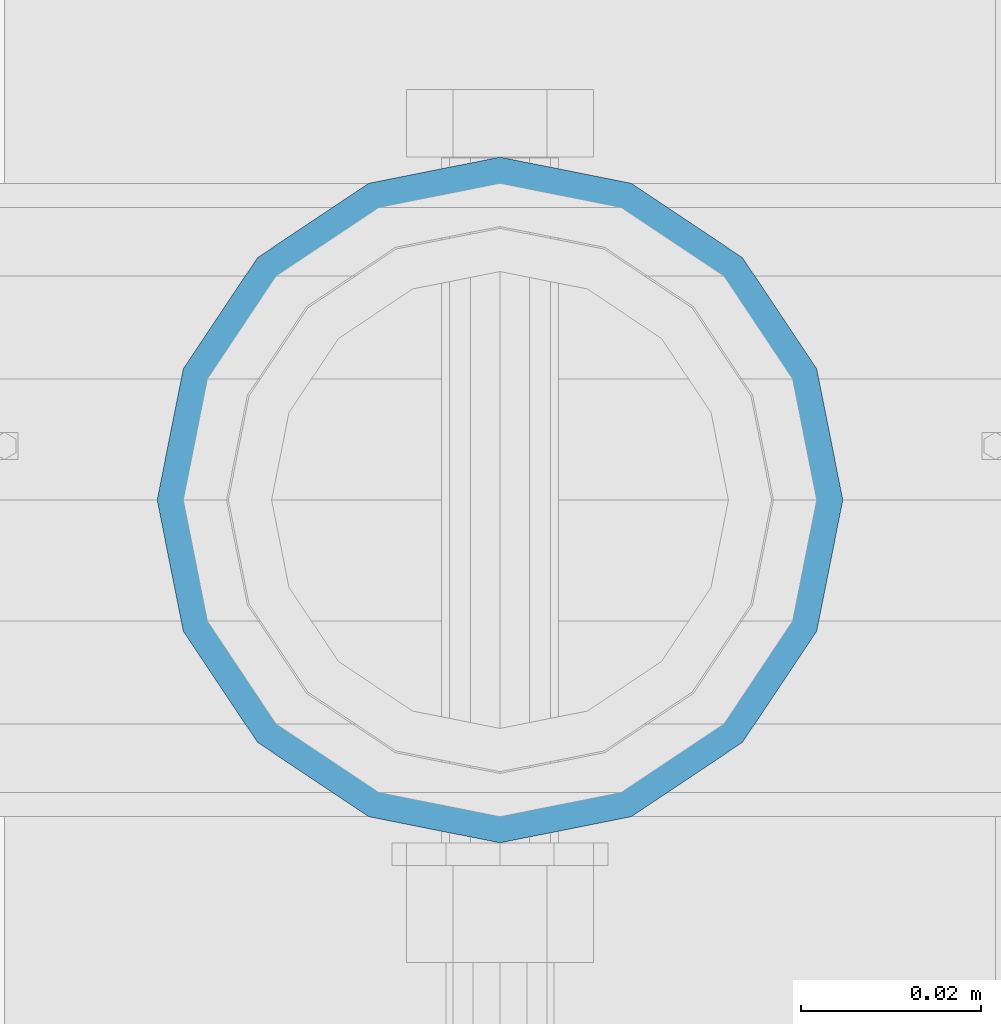
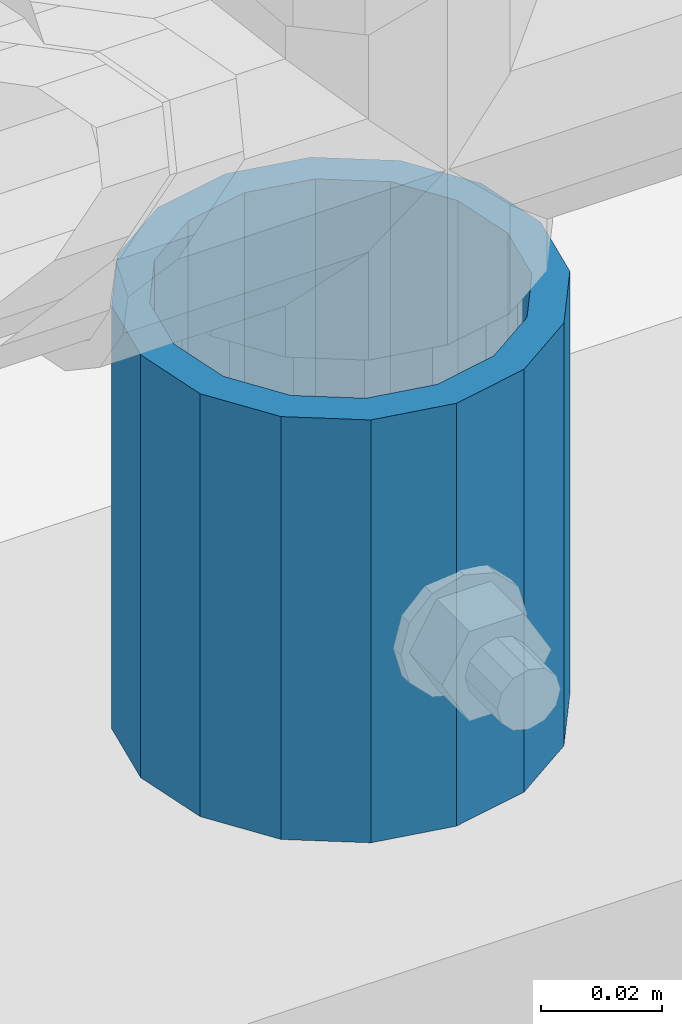
# One storey, part 79 of 240: 1 column.
"""IFC2X3 building model written with IfcOpenShell, lengths in millimetres."""

from ifc_helpers import new_model, si_unit, frame, origin_with_axes, place, context, subcontext, project, spatial, faceted_brep, material, type_object, element, save


model = new_model("IFC2X3")

# Units and contexts
model_context = context("Model", 3, precision=1e-05, world=origin_with_axes())
body_context = subcontext(model_context, "Body", "Model", "MODEL_VIEW")
ifc_project = project(units=[si_unit("LENGTHUNIT", "METRE", prefix="MILLI"), si_unit("AREAUNIT", "SQUARE_METRE"), si_unit("VOLUMEUNIT", "CUBIC_METRE"), si_unit("MASSUNIT", "GRAM", prefix="KILO"), si_unit("TIMEUNIT", "SECOND"), si_unit("PLANEANGLEUNIT", "RADIAN"), si_unit("SOLIDANGLEUNIT", "STERADIAN"), si_unit("THERMODYNAMICTEMPERATUREUNIT", "DEGREE_CELSIUS"), si_unit("LUMINOUSINTENSITYUNIT", "LUMEN")], contexts=[model_context])

# Site, building, storey
site_placement = place(None, origin_with_axes())
site = spatial("IfcSite", under=ifc_project, at=site_placement, CompositionType="ELEMENT")
building_placement = place(site_placement, origin_with_axes())
building = spatial("IfcBuilding", under=site, at=building_placement, Name="Standard", CompositionType="ELEMENT")
storey_placement = place(building_placement, origin_with_axes())
storey = spatial("IfcBuildingStorey", under=building, at=storey_placement, Name="Undefined", CompositionType="ELEMENT", Elevation=0.0)

# Column
ifc_material = material()
column_type = type_object("IfcColumnType", PredefinedType="NOTDEFINED")
column_placement = place(storey_placement, frame((48045.0, 34664.5, 168.02), z_axis=(0.0, 1.0, 0.0), x_axis=(0.0, 0.0, 1.0)))
element("IfcColumn", 1, at=column_placement, inside=storey, type_object=column_type, material=ifc_material, context=body_context, shape_type="Brep", body=[
    faceted_brep([(0.0, -31.75, 0.0), (0.0, -29.3331751572332, 12.1501989775934), (85.0, -29.3331751572332, 12.1501989775934), (85.0, -31.75, 0.0), (0.0, -22.4506403026753, 22.4506403026753), (85.0, -22.4506403026753, 22.4506403026753), (0.0, -12.1501989775934, 29.3331751572332), (85.0, -12.1501989775934, 29.3331751572332), (0.0, 0.0, 31.75), (85.0, 0.0, 31.75), (0.0, 12.1501989775934, 29.3331751572332), (85.0, 12.1501989775934, 29.3331751572332), (0.0, 22.4506403026753, 22.4506403026753), (85.0, 22.4506403026753, 22.4506403026753), (0.0, 29.3331751572332, 12.1501989775934), (85.0, 29.3331751572332, 12.1501989775934), (0.0, 31.75, 0.0), (85.0, 31.75, 0.0), (0.0, 29.3331751572332, -12.1501989775934), (85.0, 29.3331751572332, -12.1501989775934), (0.0, 22.4506403026753, -22.4506403026753), (85.0, 22.4506403026753, -22.4506403026753), (0.0, 12.1501989775934, -29.3331751572332), (85.0, 12.1501989775934, -29.3331751572332), (0.0, 0.0, -31.75), (85.0, 0.0, -31.75), (0.0, -12.1501989775934, -29.3331751572332), (85.0, -12.1501989775934, -29.3331751572332), (0.0, -22.4506403026753, -22.4506403026753), (85.0, -22.4506403026753, -22.4506403026753), (0.0, -29.3331751572332, -12.1501989775934), (85.0, -29.3331751572332, -12.1501989775934), (0.0, -38.0500000000029, 0.0), (0.0, -35.1536162120537, -14.5611046014892), (85.0, -35.1536162120537, -14.5611046014892), (85.0, -38.0500000000029, 0.0), (0.0, -26.9054130241493, -26.9054130241493), (85.0, -26.9054130241493, -26.9054130241493), (0.0, -14.5611046014892, -35.1536162120537), (85.0, -14.5611046014892, -35.1536162120537), (0.0, 0.0, -38.0500000000029), (85.0, 0.0, -38.0500000000029), (0.0, 14.5611046014892, -35.1536162120537), (85.0, 14.5611046014892, -35.1536162120537), (0.0, 26.9054130241493, -26.9054130241493), (85.0, 26.9054130241493, -26.9054130241493), (0.0, 35.1536162120537, -14.5611046014892), (85.0, 35.1536162120537, -14.5611046014892), (0.0, 38.0500000000029, 0.0), (85.0, 38.0500000000029, 0.0), (0.0, 35.1536162120537, 14.5611046014892), (85.0, 35.1536162120537, 14.5611046014892), (0.0, 26.9054130241493, 26.9054130241493), (85.0, 26.9054130241493, 26.9054130241493), (0.0, 14.5611046014892, 35.1536162120537), (85.0, 14.5611046014892, 35.1536162120537), (0.0, 0.0, 38.0500000000029), (85.0, 0.0, 38.0500000000029), (0.0, -14.5611046014892, 35.1536162120537), (85.0, -14.5611046014892, 35.1536162120537), (0.0, -26.9054130241493, 26.9054130241493), (85.0, -26.9054130241493, 26.9054130241493), (0.0, -35.1536162120537, 14.5611046014892), (85.0, -35.1536162120537, 14.5611046014892)], [[[0, 1, 2, 3]], [[1, 4, 5, 2]], [[4, 6, 7, 5]], [[6, 8, 9, 7]], [[8, 10, 11, 9]], [[10, 12, 13, 11]], [[12, 14, 15, 13]], [[14, 16, 17, 15]], [[16, 18, 19, 17]], [[18, 20, 21, 19]], [[20, 22, 23, 21]], [[22, 24, 25, 23]], [[24, 26, 27, 25]], [[26, 28, 29, 27]], [[28, 30, 31, 29]], [[30, 0, 3, 31]], [[32, 33, 34, 35]], [[33, 36, 37, 34]], [[36, 38, 39, 37]], [[38, 40, 41, 39]], [[40, 42, 43, 41]], [[42, 44, 45, 43]], [[44, 46, 47, 45]], [[46, 48, 49, 47]], [[48, 50, 51, 49]], [[50, 52, 53, 51]], [[52, 54, 55, 53]], [[54, 56, 57, 55]], [[56, 58, 59, 57]], [[58, 60, 61, 59]], [[60, 62, 63, 61]], [[62, 32, 35, 63]], [[37, 39, 41, 43, 45, 47, 49, 51, 53, 55, 57, 59, 61, 63, 35, 34], [5, 7, 9, 11, 13, 15, 17, 19, 21, 23, 25, 27, 29, 31, 3, 2]], [[62, 60, 58, 56, 54, 52, 50, 48, 46, 44, 42, 40, 38, 36, 33, 32], [30, 28, 26, 24, 22, 20, 18, 16, 14, 12, 10, 8, 6, 4, 1, 0]]]),
])

save(model, "model.ifc")
